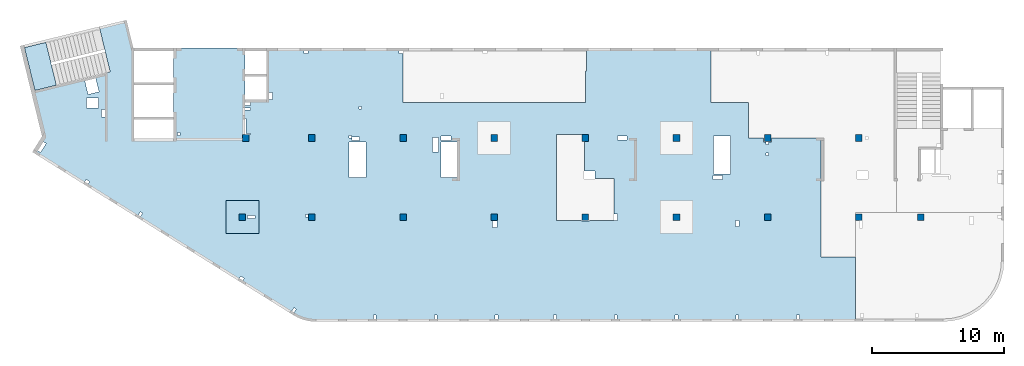
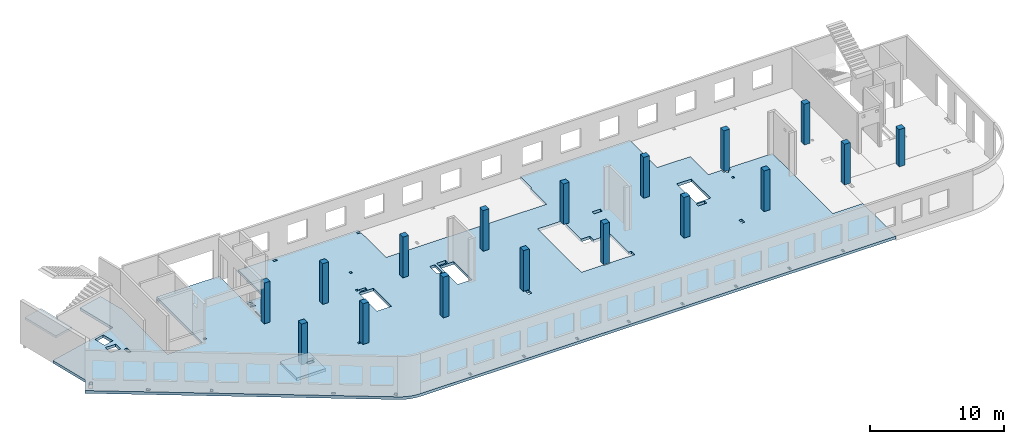
# One storey, part 1 of 6: 17 columns, 3 slabs.
"""IFC4 building model written with IfcOpenShell, lengths in millimetres."""

from ifc_helpers import new_model, entity, si_unit, converted_unit, derived_unit, direction, frame, origin, place, context, subcontext, project, spatial, indexed_curve, outline, extrude, source, transform, mapped, material, type_object, type_shapes, element, save


model = new_model("IFC4")

# Units and contexts
model_context = context("Model", 3, precision=0.01, world=origin(), true_north=direction((6.12303176911189e-17, 1.0)))
plan_context = context("Plan", 3, precision=0.01, world=origin(), true_north=direction((6.12303176911189e-17, 1.0)))
body_context = subcontext(model_context, "Body", "Model", "MODEL_VIEW")
ifc_project = project(units=[si_unit("LENGTHUNIT", "METRE", prefix="MILLI"), si_unit("AREAUNIT", "SQUARE_METRE"), si_unit("VOLUMEUNIT", "CUBIC_METRE"), converted_unit("PLANEANGLEUNIT", "DEGREE", entity("IfcRatioMeasure", 0.0174532925199433), si_unit("PLANEANGLEUNIT", "RADIAN"), dimensions=[0, 0, 0, 0, 0, 0, 0]), si_unit("MASSUNIT", "GRAM", prefix="KILO"), derived_unit("MASSDENSITYUNIT", [(si_unit("MASSUNIT", "GRAM", prefix="KILO"), 1), (si_unit("LENGTHUNIT", "METRE"), -3)]), derived_unit("MOMENTOFINERTIAUNIT", [(si_unit("LENGTHUNIT", "METRE"), 4)]), si_unit("TIMEUNIT", "SECOND"), si_unit("FREQUENCYUNIT", "HERTZ"), si_unit("THERMODYNAMICTEMPERATUREUNIT", "DEGREE_CELSIUS"), derived_unit("THERMALTRANSMITTANCEUNIT", [(si_unit("MASSUNIT", "GRAM", prefix="KILO"), 1), (si_unit("THERMODYNAMICTEMPERATUREUNIT", "KELVIN"), -1), (si_unit("TIMEUNIT", "SECOND"), -3)]), derived_unit("VOLUMETRICFLOWRATEUNIT", [(si_unit("LENGTHUNIT", "METRE"), 3), (si_unit("TIMEUNIT", "SECOND"), -1)]), derived_unit("MASSFLOWRATEUNIT", [(si_unit("MASSUNIT", "GRAM", prefix="KILO"), 1), (si_unit("TIMEUNIT", "SECOND"), -1)]), derived_unit("ROTATIONALFREQUENCYUNIT", [(si_unit("TIMEUNIT", "SECOND"), -1)]), si_unit("ELECTRICCURRENTUNIT", "AMPERE"), si_unit("ELECTRICVOLTAGEUNIT", "VOLT"), si_unit("POWERUNIT", "WATT"), si_unit("FORCEUNIT", "NEWTON", prefix="KILO"), si_unit("ILLUMINANCEUNIT", "LUX"), si_unit("LUMINOUSFLUXUNIT", "LUMEN"), si_unit("LUMINOUSINTENSITYUNIT", "CANDELA"), derived_unit("USERDEFINED", [(si_unit("MASSUNIT", "GRAM", prefix="KILO"), -1), (si_unit("LENGTHUNIT", "METRE"), -2), (si_unit("TIMEUNIT", "SECOND"), 3), (si_unit("LUMINOUSFLUXUNIT", "LUMEN"), 1)]), derived_unit("LINEARVELOCITYUNIT", [(si_unit("LENGTHUNIT", "METRE"), 1), (si_unit("TIMEUNIT", "SECOND"), -1)]), si_unit("PRESSUREUNIT", "PASCAL"), derived_unit("USERDEFINED", [(si_unit("LENGTHUNIT", "METRE"), -2), (si_unit("MASSUNIT", "GRAM", prefix="KILO"), 1), (si_unit("TIMEUNIT", "SECOND"), -2)]), derived_unit("LINEARFORCEUNIT", [(si_unit("MASSUNIT", "GRAM", prefix="KILO"), 1), (si_unit("LENGTHUNIT", "METRE"), 1), (si_unit("TIMEUNIT", "SECOND"), -2), (si_unit("LENGTHUNIT", "METRE"), -1)]), derived_unit("PLANARFORCEUNIT", [(si_unit("MASSUNIT", "GRAM", prefix="KILO"), 1), (si_unit("LENGTHUNIT", "METRE"), 1), (si_unit("TIMEUNIT", "SECOND"), -2), (si_unit("LENGTHUNIT", "METRE"), -2)])], contexts=[model_context, plan_context])

# Site, building, storey
site_placement = place(None, origin())
site = spatial("IfcSite", under=ifc_project, at=site_placement, CompositionType="ELEMENT")
building_placement = place(site_placement, origin())
building = spatial("IfcBuilding", under=site, at=building_placement, CompositionType="ELEMENT")
storey_placement = place(building_placement, frame((0.0, 0.0, 8100.0)))
storey = spatial("IfcBuildingStorey", under=building, at=storey_placement, CompositionType="ELEMENT", Elevation=8100.0)

# Columns
ifc_material = material()
column_type_1 = type_object("IfcColumnType", PredefinedType="COLUMN", material=ifc_material)
shared_shape_1 = source(origin(), body_context, "Body", "SweptSolid", [
    extrude(outline(indexed_curve([(-249.999999999999, -249.999999999999), (250.000000000001, -249.999999999999), (249.999999999999, 249.999999999999), (-250.000000000001, 249.999999999999), (-249.999999999999, -249.999999999999)], self_intersect=False)), frame((15899.9995239258, 7699.99922635584, 7950.0), z_axis=(0.0, 0.0, 1.0), x_axis=(0.0, -1.0, 0.0)), (0.0, 0.0, 1.0), 3700.0),
])
type_shapes(column_type_1, [shared_shape_1])
column_1_placement = place(storey_placement, frame((0.0, 0.0, -8100.0)))
element("IfcColumn", 1, at=column_1_placement, inside=storey, type_object=column_type_1, PredefinedType="COLUMN", context=body_context, shape_type="MappedRepresentation", body=[
    mapped(shared_shape_1, transform((0.0, 0.0, 0.0), scale=1.0)),
])
column_type_2 = type_object("IfcColumnType", PredefinedType="COLUMN", material=ifc_material)
shared_shape_2 = source(origin(), body_context, "Body", "SweptSolid", [
    extrude(outline(indexed_curve([(-249.999999999999, -249.999999999999), (250.000000000001, -249.999999999999), (249.999999999999, 249.999999999999), (-250.000000000001, 249.999999999999), (-249.999999999999, -249.999999999999)], self_intersect=False)), frame((21170.0002685547, 7699.99922635582, 7950.0), z_axis=(0.0, 0.0, 1.0), x_axis=(0.0, -1.0, 0.0)), (0.0, 0.0, 1.0), 3700.0),
])
type_shapes(column_type_2, [shared_shape_2])
column_2_placement = place(storey_placement, frame((0.0, 0.0, -8100.0)))
element("IfcColumn", 2, at=column_2_placement, inside=storey, type_object=column_type_2, PredefinedType="COLUMN", context=body_context, shape_type="MappedRepresentation", body=[
    mapped(shared_shape_2, transform((0.0, 0.0, 0.0), scale=1.0)),
])
column_type_3 = type_object("IfcColumnType", PredefinedType="COLUMN", material=ifc_material)
shared_shape_3 = source(origin(), body_context, "Body", "SweptSolid", [
    extrude(outline(indexed_curve([(-249.999999999999, -249.999999999999), (250.000000000001, -249.999999999999), (250.000000000001, 249.999999999999), (-249.999999999999, 249.999999999999), (-249.999999999999, -249.999999999999)], self_intersect=False)), frame((28070.0002685547, 7699.9992263558, 7950.0), z_axis=(0.0, 0.0, 1.0), x_axis=(0.0, -1.0, 0.0)), (0.0, 0.0, 1.0), 3700.0),
])
type_shapes(column_type_3, [shared_shape_3])
column_3_placement = place(storey_placement, frame((0.0, 0.0, -8100.0)))
element("IfcColumn", 3, at=column_3_placement, inside=storey, type_object=column_type_3, PredefinedType="COLUMN", context=body_context, shape_type="MappedRepresentation", body=[
    mapped(shared_shape_3, transform((0.0, 0.0, 0.0), scale=1.0)),
])
column_type_4 = type_object("IfcColumnType", PredefinedType="COLUMN", material=ifc_material)
shared_shape_4 = source(origin(), body_context, "Body", "SweptSolid", [
    extrude(outline(indexed_curve([(-249.999999999999, -249.999999999999), (250.000000000001, -249.999999999999), (249.999999999999, 249.999999999999), (-250.000000000001, 249.999999999999), (-249.999999999999, -249.999999999999)], self_intersect=False)), frame((34970.0002685547, 7699.99922635577, 7950.0), z_axis=(0.0, 0.0, 1.0), x_axis=(0.0, -1.0, 0.0)), (0.0, 0.0, 1.0), 3700.0),
])
type_shapes(column_type_4, [shared_shape_4])
column_4_placement = place(storey_placement, frame((0.0, 0.0, -8100.0)))
element("IfcColumn", 4, at=column_4_placement, inside=storey, type_object=column_type_4, PredefinedType="COLUMN", context=body_context, shape_type="MappedRepresentation", body=[
    mapped(shared_shape_4, transform((0.0, 0.0, 0.0), scale=1.0)),
])
column_type_5 = type_object("IfcColumnType", PredefinedType="COLUMN", material=ifc_material)
shared_shape_5 = source(origin(), body_context, "Body", "SweptSolid", [
    extrude(outline(indexed_curve([(-249.999999999999, -250.000000000004), (250.000000000001, -250.000000000004), (250.000000000001, 249.999999999995), (-249.999999999999, 250.000000000004), (-249.999999999999, -250.000000000004)], self_intersect=False)), frame((41870.0002685547, 7699.99922635575, 7950.0), z_axis=(0.0, 0.0, 1.0), x_axis=(0.0, -1.0, 0.0)), (0.0, 0.0, 1.0), 3700.0),
])
type_shapes(column_type_5, [shared_shape_5])
column_5_placement = place(storey_placement, frame((0.0, 0.0, -8100.0)))
element("IfcColumn", 5, at=column_5_placement, inside=storey, type_object=column_type_5, PredefinedType="COLUMN", context=body_context, shape_type="MappedRepresentation", body=[
    mapped(shared_shape_5, transform((0.0, 0.0, 0.0), scale=1.0)),
])
column_type_6 = type_object("IfcColumnType", PredefinedType="COLUMN", material=ifc_material)
shared_shape_6 = source(origin(), body_context, "Body", "SweptSolid", [
    extrude(outline(indexed_curve([(-249.999999999999, -250.000000000004), (250.000000000001, -250.000000000004), (249.999999999999, 249.999999999995), (-250.000000000001, 250.000000000004), (-249.999999999999, -250.000000000004)], self_intersect=False)), frame((48770.0002685547, 7699.99922635573, 7950.0), z_axis=(0.0, 0.0, 1.0), x_axis=(0.0, -1.0, 0.0)), (0.0, 0.0, 1.0), 3700.0),
])
type_shapes(column_type_6, [shared_shape_6])
column_6_placement = place(storey_placement, frame((0.0, 0.0, -8100.0)))
element("IfcColumn", 6, at=column_6_placement, inside=storey, type_object=column_type_6, PredefinedType="COLUMN", context=body_context, shape_type="MappedRepresentation", body=[
    mapped(shared_shape_6, transform((0.0, 0.0, 0.0), scale=1.0)),
])
column_type_7 = type_object("IfcColumnType", PredefinedType="COLUMN", material=ifc_material)
shared_shape_7 = source(origin(), body_context, "Body", "SweptSolid", [
    extrude(outline(indexed_curve([(-249.999999999999, -250.000000000004), (250.000000000001, -250.000000000004), (250.000000000001, 249.999999999995), (-249.999999999999, 250.000000000004), (-249.999999999999, -250.000000000004)], self_intersect=False)), frame((55670.0002685547, 7699.99922635571, 7950.0), z_axis=(0.0, 0.0, 1.0), x_axis=(0.0, -1.0, 0.0)), (0.0, 0.0, 1.0), 3700.0),
])
type_shapes(column_type_7, [shared_shape_7])
column_7_placement = place(storey_placement, frame((0.0, 0.0, -8100.0)))
element("IfcColumn", 7, at=column_7_placement, inside=storey, type_object=column_type_7, PredefinedType="COLUMN", context=body_context, shape_type="MappedRepresentation", body=[
    mapped(shared_shape_7, transform((0.0, 0.0, 0.0), scale=1.0)),
])
column_type_8 = type_object("IfcColumnType", PredefinedType="COLUMN", material=ifc_material)
shared_shape_8 = source(origin(), body_context, "Body", "SweptSolid", [
    extrude(outline(indexed_curve([(-249.999999999999, -250.000000000004), (250.000000000001, -250.000000000004), (249.999999999999, 249.999999999995), (-250.000000000001, 250.000000000004), (-249.999999999999, -250.000000000004)], self_intersect=False)), frame((62570.0002685547, 7699.99922635568, 7950.0), z_axis=(0.0, 0.0, 1.0), x_axis=(0.0, -1.0, 0.0)), (0.0, 0.0, 1.0), 3700.0),
])
type_shapes(column_type_8, [shared_shape_8])
column_8_placement = place(storey_placement, frame((0.0, 0.0, -8100.0)))
element("IfcColumn", 8, at=column_8_placement, inside=storey, type_object=column_type_8, PredefinedType="COLUMN", context=body_context, shape_type="MappedRepresentation", body=[
    mapped(shared_shape_8, transform((0.0, 0.0, 0.0), scale=1.0)),
])
column_type_9 = type_object("IfcColumnType", PredefinedType="COLUMN", material=ifc_material)
shared_shape_9 = source(origin(), body_context, "Body", "SweptSolid", [
    extrude(outline(indexed_curve([(-249.999999999999, -250.000000000004), (250.000000000001, -250.000000000004), (249.999999999999, 249.999999999995), (-250.000000000001, 250.000000000004), (-249.999999999999, -250.000000000004)], self_intersect=False)), frame((67270.0002685547, 7699.99922635567, 7950.0), z_axis=(0.0, 0.0, 1.0), x_axis=(0.0, -1.0, 0.0)), (0.0, 0.0, 1.0), 3400.0),
])
type_shapes(column_type_9, [shared_shape_9])
column_9_placement = place(storey_placement, frame((0.0, 0.0, -8100.0)))
element("IfcColumn", 9, at=column_9_placement, inside=storey, type_object=column_type_9, PredefinedType="COLUMN", context=body_context, shape_type="MappedRepresentation", body=[
    mapped(shared_shape_9, transform((0.0, 0.0, 0.0), scale=1.0)),
])
column_type_10 = type_object("IfcColumnType", PredefinedType="COLUMN", material=ifc_material)
shared_shape_10 = source(origin(), body_context, "Body", "SweptSolid", [
    extrude(outline(indexed_curve([(-249.999999999999, -250.000000000004), (249.999999999999, -250.000000000004), (249.999999999999, 249.999999999995), (-249.999999999999, 250.000000000004), (-249.999999999999, -250.000000000004)], self_intersect=False)), frame((62570.0002685547, 13699.9992263555, 7950.0), z_axis=(0.0, 0.0, 1.0), x_axis=(0.0, -1.0, 0.0)), (0.0, 0.0, 1.0), 3700.0),
])
type_shapes(column_type_10, [shared_shape_10])
column_10_placement = place(storey_placement, frame((0.0, 0.0, -8100.0)))
element("IfcColumn", 10, at=column_10_placement, inside=storey, type_object=column_type_10, PredefinedType="COLUMN", context=body_context, shape_type="MappedRepresentation", body=[
    mapped(shared_shape_10, transform((0.0, 0.0, 0.0), scale=1.0)),
])
column_type_11 = type_object("IfcColumnType", PredefinedType="COLUMN", material=ifc_material)
shared_shape_11 = source(origin(), body_context, "Body", "SweptSolid", [
    extrude(outline(indexed_curve([(-249.999999999999, -250.000000000004), (249.999999999999, -250.000000000004), (249.999999999999, 249.999999999995), (-249.999999999999, 250.000000000004), (-249.999999999999, -250.000000000004)], self_intersect=False)), frame((55670.0002685547, 13699.9992263555, 7950.0), z_axis=(0.0, 0.0, 1.0), x_axis=(0.0, -1.0, 0.0)), (0.0, 0.0, 1.0), 3700.0),
])
type_shapes(column_type_11, [shared_shape_11])
column_11_placement = place(storey_placement, frame((0.0, 0.0, -8100.0)))
element("IfcColumn", 11, at=column_11_placement, inside=storey, type_object=column_type_11, PredefinedType="COLUMN", context=body_context, shape_type="MappedRepresentation", body=[
    mapped(shared_shape_11, transform((0.0, 0.0, 0.0), scale=1.0)),
])
column_type_12 = type_object("IfcColumnType", PredefinedType="COLUMN", material=ifc_material)
shared_shape_12 = source(origin(), body_context, "Body", "SweptSolid", [
    extrude(outline(indexed_curve([(-249.999999999999, -250.000000000004), (249.999999999999, -250.000000000004), (249.999999999999, 249.999999999995), (-249.999999999999, 250.000000000004), (-249.999999999999, -250.000000000004)], self_intersect=False)), frame((48770.0002685547, 13699.9992263556, 7950.0), z_axis=(0.0, 0.0, 1.0), x_axis=(0.0, -1.0, 0.0)), (0.0, 0.0, 1.0), 3700.0),
])
type_shapes(column_type_12, [shared_shape_12])
column_12_placement = place(storey_placement, frame((0.0, 0.0, -8100.0)))
element("IfcColumn", 12, at=column_12_placement, inside=storey, type_object=column_type_12, PredefinedType="COLUMN", context=body_context, shape_type="MappedRepresentation", body=[
    mapped(shared_shape_12, transform((0.0, 0.0, 0.0), scale=1.0)),
])
column_type_13 = type_object("IfcColumnType", PredefinedType="COLUMN", material=ifc_material)
shared_shape_13 = source(origin(), body_context, "Body", "SweptSolid", [
    extrude(outline(indexed_curve([(-249.999999999999, -250.000000000004), (249.999999999999, -250.000000000004), (249.999999999999, 249.999999999995), (-249.999999999999, 250.000000000004), (-249.999999999999, -250.000000000004)], self_intersect=False)), frame((41870.0002685547, 13699.9992263556, 7950.0), z_axis=(0.0, 0.0, 1.0), x_axis=(0.0, -1.0, 0.0)), (0.0, 0.0, 1.0), 3700.0),
])
type_shapes(column_type_13, [shared_shape_13])
column_13_placement = place(storey_placement, frame((0.0, 0.0, -8100.0)))
element("IfcColumn", 13, at=column_13_placement, inside=storey, type_object=column_type_13, PredefinedType="COLUMN", context=body_context, shape_type="MappedRepresentation", body=[
    mapped(shared_shape_13, transform((0.0, 0.0, 0.0), scale=1.0)),
])
column_type_14 = type_object("IfcColumnType", PredefinedType="COLUMN", material=ifc_material)
shared_shape_14 = source(origin(), body_context, "Body", "SweptSolid", [
    extrude(outline(indexed_curve([(-249.999999999999, -249.999999999999), (249.999999999999, -249.999999999999), (249.999999999999, 249.999999999999), (-249.999999999999, 249.999999999999), (-249.999999999999, -249.999999999999)], self_intersect=False)), frame((34970.0002685547, 13699.9992263556, 7950.0), z_axis=(0.0, 0.0, 1.0), x_axis=(0.0, -1.0, 0.0)), (0.0, 0.0, 1.0), 3700.0),
])
type_shapes(column_type_14, [shared_shape_14])
column_14_placement = place(storey_placement, frame((0.0, 0.0, -8100.0)))
element("IfcColumn", 14, at=column_14_placement, inside=storey, type_object=column_type_14, PredefinedType="COLUMN", context=body_context, shape_type="MappedRepresentation", body=[
    mapped(shared_shape_14, transform((0.0, 0.0, 0.0), scale=1.0)),
])
column_type_15 = type_object("IfcColumnType", PredefinedType="COLUMN", material=ifc_material)
shared_shape_15 = source(origin(), body_context, "Body", "SweptSolid", [
    extrude(outline(indexed_curve([(-249.999999999999, -249.999999999999), (249.999999999999, -249.999999999999), (249.999999999999, 249.999999999999), (-249.999999999999, 249.999999999999), (-249.999999999999, -249.999999999999)], self_intersect=False)), frame((28070.0002685547, 13699.9992263556, 7950.0), z_axis=(0.0, 0.0, 1.0), x_axis=(0.0, -1.0, 0.0)), (0.0, 0.0, 1.0), 3700.0),
])
type_shapes(column_type_15, [shared_shape_15])
column_15_placement = place(storey_placement, frame((0.0, 0.0, -8100.0)))
element("IfcColumn", 15, at=column_15_placement, inside=storey, type_object=column_type_15, PredefinedType="COLUMN", context=body_context, shape_type="MappedRepresentation", body=[
    mapped(shared_shape_15, transform((0.0, 0.0, 0.0), scale=1.0)),
])
column_type_16 = type_object("IfcColumnType", PredefinedType="COLUMN", material=ifc_material)
shared_shape_16 = source(origin(), body_context, "Body", "SweptSolid", [
    extrude(outline(indexed_curve([(-249.999999999999, -249.999999999999), (249.999999999999, -249.999999999999), (249.999999999999, 249.999999999999), (-249.999999999999, 249.999999999999), (-249.999999999999, -249.999999999999)], self_intersect=False)), frame((21170.0002685547, 13699.9992263556, 7950.0), z_axis=(0.0, 0.0, 1.0), x_axis=(0.0, -1.0, 0.0)), (0.0, 0.0, 1.0), 3700.0),
])
type_shapes(column_type_16, [shared_shape_16])
column_16_placement = place(storey_placement, frame((0.0, 0.0, -8100.0)))
element("IfcColumn", 16, at=column_16_placement, inside=storey, type_object=column_type_16, PredefinedType="COLUMN", context=body_context, shape_type="MappedRepresentation", body=[
    mapped(shared_shape_16, transform((0.0, 0.0, 0.0), scale=1.0)),
])
column_type_17 = type_object("IfcColumnType", PredefinedType="COLUMN", material=ifc_material)
shared_shape_17 = source(origin(), body_context, "Body", "SweptSolid", [
    extrude(outline(indexed_curve([(-249.999999999999, -249.999999999999), (249.999999999999, -249.999999999999), (249.999999999999, 249.999999999999), (-249.999999999999, 249.999999999999), (-249.999999999999, -249.999999999999)], self_intersect=False)), frame((16160.0002685547, 13699.9992263558, 7950.0), z_axis=(0.0, 0.0, 1.0), x_axis=(0.0, -1.0, 0.0)), (0.0, 0.0, 1.0), 3700.0),
])
type_shapes(column_type_17, [shared_shape_17])
column_17_placement = place(storey_placement, frame((0.0, 0.0, -8100.0)))
element("IfcColumn", 17, at=column_17_placement, inside=storey, type_object=column_type_17, PredefinedType="COLUMN", context=body_context, shape_type="MappedRepresentation", body=[
    mapped(shared_shape_17, transform((0.0, 0.0, 0.0), scale=1.0)),
])

# Slabs
slab_type_1 = type_object("IfcSlabType", PredefinedType="FLOOR", material=ifc_material)
slab_1_placement = place(storey_placement, origin())
element("IfcSlab", 18, at=slab_1_placement, inside=storey, type_object=slab_type_1, material=ifc_material, PredefinedType="FLOOR", context=body_context, shape_type="SweptSolid", body=[
    extrude(outline(indexed_curve([(-4918.44093092507, 21194.7161822057), (-4918.44093092504, 15794.7161822057), (-1018.44093092502, 15794.7161822057), (-1018.44093092502, 14169.7161822057), (-4918.44093092503, 14169.7161822057), (-4918.44093092499, 3824.71618220575), (-4718.44157029135, 3824.71618220575), (-4718.44157029135, 4124.71618220581), (-4518.44197312357, 4124.71618220581), (-4518.44197312357, 3824.71618220575), (-818.440930924992, 3824.71618220575), (-818.440930924947, -9975.28381779424), (-3198.44093092485, -9975.28381779424), (-3198.44093092485, -10075.2838177942), (-4918.44093092494, -10075.2838177942), (-4918.44093092491, -19495.2838177944), (-818.440930924876, -19495.2838177942), (-818.440930924728, -22325.2838177944), (1881.5590690752, -22325.2838177942), (1881.55906907526, -23475.2838177943), (2181.5590690751, -23475.2838177943), (2181.5590690751, -23650.2838177942), (2371.55802687642, -23650.2838177942), (2371.55802687642, -23850.2838177942), (2181.5590690751, -23850.2838177942), (2181.5590690751, -24075.2838177943), (1881.55906907526, -24075.2838177943), (1881.55906907527, -27835.2838177942), (10881.5590690753, -27835.2838177942), (10881.5590690753, -30425.2838177942), (15782.0128580296, -30425.2838177942), (15782.0128580296, 10427.6716031478), (15777.0106740912, 10606.4915509534), (15762.0197669795, 10784.7522260372), (15737.0870218744, 10961.8961048444), (15702.2904177954, 11137.3691566841), (15657.7387837167, 11310.6225765011), (15603.5714581962, 11481.1145013049), (15539.9578535838, 11648.3117048867), (15467.0969261719, 11811.691265524), (15385.2165539443, 11970.7422014573), (15294.5728238713, 12124.9670690234), (2942.09072966658, 31894.8565409199), (1763.37987869352, 31158.3306297265), (-1646.92724838292, 31989.6290722903), (-3108.1423640225, 25995.1605782929), (-6547.43664984333, 26833.5249474787), (-7051.87622791275, 24764.1190636373), (-4918.44093092509, 24244.0716386956), (-4918.44093092509, 24194.7161822057), (1931.55906907492, 24194.7161822058), (1931.55906907493, 21194.7161822057), (-4918.44093092507, 21194.7161822057)], self_intersect=False), holes=[indexed_curve([(1631.55906907515, -7800.28381779424), (7881.55906907513, -7800.28381779422), (8131.55906907513, -7800.28381779422), (8131.55906907513, -9675.28381779422), (8181.55906907513, -9675.28381779422), (8181.55906907513, -9975.28381779428), (8181.55906907513, -10275.2838177943), (8131.55906907513, -10275.2838177943), (8131.55802687643, -12400.2838177942), (7631.55802687644, -12400.2838177942), (7631.55802687644, -12150.2838177943), (4956.55906907508, -12150.2838177943), (4956.55906907509, -10690.2838177942), (4396.55906907515, -10690.2838177942), (4396.55906907515, -9925.28381779424), (2081.55906907572, -9925.28381779424), (2081.55906907572, -10225.2838177943), (1631.55906907515, -10225.2838177943), (1631.55906907515, -7800.28381779424)], self_intersect=False), indexed_curve([(-2433.4077366988, 27918.680956152), (-1413.3021088605, 27670.0194168614), (-1614.60687707192, 26844.1895456677), (-2634.71250491022, 27092.8510849583), (-2433.4077366988, 27918.680956152)], self_intersect=False), indexed_curve([(-1128.44197312358, 26884.7161822058), (-1128.44197312358, 27784.7161822058), (-388.441973123572, 27784.7161822058), (-388.441973123572, 26884.7161822058), (-1128.44197312358, 26884.7161822058)], self_intersect=False), indexed_curve([(-268.441973123565, 26394.7161822058), (-268.441973123565, 26644.7161822058), (291.558026876412, 26644.7161822058), (291.558026876412, 26394.7161822058), (-268.441973123565, 26394.7161822058)], self_intersect=False), indexed_curve([(2300.46693601222, 30845.3844889143), (2167.98706279423, 31057.4007421437), (2846.42925781629, 31481.3302032733), (2978.90913103428, 31269.313950044), (2300.46693601222, 30845.3844889143)], self_intersect=False), indexed_curve([(7467.44226277405, 23709.0856761198), (7721.85808590733, 23868.0592240434), (7827.84184543901, 23698.4464439791), (7573.42602230574, 23539.4728960555), (7467.44226277405, 23709.0856761198)], self_intersect=False), indexed_curve([(12496.324877766, 15849.7447590121), (12337.3522593331, 16104.1590946203), (12506.9628080886, 16210.1414599027), (12665.9354265215, 15955.7271242945), (12496.324877766, 15849.7447590121)], self_intersect=False), indexed_curve([(14729.8838440301, 12086.5228222013), (14984.2996671633, 12245.4963701249), (15090.283426695, 12075.8835900606), (14835.8676035617, 11916.910042137), (14729.8838440301, 12086.5228222013)], self_intersect=False), indexed_curve([(7731.55802687642, 15044.7161822058), (7731.55802687642, 15604.7161822058), (7981.55802687643, 15604.7161822058), (7981.55802687643, 15044.7161822058), (7731.55802687642, 15044.7161822058)], self_intersect=False), indexed_curve([(1481.55802687642, 20694.7161822058), (1481.55802687642, 20894.7161822058), (1681.55802687644, 20894.7161822058), (1681.55802687644, 20694.7161822058), (1481.55802687642, 20694.7161822058)], self_intersect=False), indexed_curve([(-818.440930924518, 15364.7161822058), (-818.440930924518, 15794.7161822057), (-568.441973123566, 15794.7161822057), (-568.441973123566, 15364.7161822058), (-818.440930924518, 15364.7161822058)], self_intersect=False), indexed_curve([(421.558026876417, 15714.7161822058), (421.558026876417, 15794.7161822057), (1611.55802687642, 15794.7161822057), (1611.55802687642, 15374.7161822058), (1531.55802687644, 15374.7161822058), (1531.55802687644, 15714.7161822058), (421.558026876417, 15714.7161822058)], self_intersect=False), indexed_curve([(-4718.44157029133, 11024.7161822058), (-4718.44157029133, 11324.7161822058), (-4518.44197312357, 11324.7161822058), (-4518.44197312357, 11024.7161822058), (-4718.44157029133, 11024.7161822058)], self_intersect=False), indexed_curve([(7681.55802687643, 11004.7161822058), (7681.55802687643, 11204.7161822058), (7881.559069075, 11204.7161822058), (7881.559069075, 11004.7161822058), (7681.55802687643, 11004.7161822058)], self_intersect=False), indexed_curve([(15281.5580268764, 5854.7161822058), (15281.5580268764, 6054.71618220579), (15581.5582512046, 6054.71618220579), (15581.5582512046, 5854.7161822058), (15281.5580268764, 5854.7161822058)], self_intersect=False), indexed_curve([(15581.5582512046, 1244.71651640657), (15281.5580268764, 1244.71651640657), (15281.5580268764, 1444.71651640656), (15581.5582512046, 1444.71651640656), (15581.5582512046, 1244.71651640657)], self_intersect=False), indexed_curve([(15581.5590690751, -3345.28348359343), (15281.5582857487, -3345.28348359343), (15281.5582857487, -3145.28348359344), (15581.5590690751, -3145.28348359344), (15581.5590690751, -3345.28348359343)], self_intersect=False), indexed_curve([(15581.5590690751, -7775.28381779419), (15281.5582857487, -7775.28381779419), (15281.5582857487, -7575.2838177942), (15581.5590690751, -7575.2838177942), (15581.5590690751, -7775.28381779419)], self_intersect=False), indexed_curve([(15581.5582512047, -12375.2834835934), (15281.5582857487, -12375.2834835934), (15281.5582857487, -12175.2834835934), (15581.5582512047, -12175.2834835934), (15581.5582512047, -12375.2834835934)], self_intersect=False), indexed_curve([(15581.5582512047, -16975.2838177942), (15281.5582857487, -16975.2838177942), (15281.5582857487, -16775.2838177942), (15581.5582512047, -16775.2838177942), (15581.5582512047, -16975.2838177942)], self_intersect=False), indexed_curve([(15281.5582857487, -21575.2834835934), (15281.5582857487, -21375.2834835934), (15581.5582512047, -21375.2834835934), (15581.5582512047, -21575.2834835934), (15281.5582857487, -21575.2834835934)], self_intersect=False), indexed_curve([(15281.5582857487, -26175.2834835934), (15281.5582857487, -25975.2834835934), (15581.5582512047, -25975.2834835934), (15581.5582512047, -26175.2834835934), (15281.5582857487, -26175.2834835934)], self_intersect=False), indexed_curve([(8581.55802687643, -21600.2838177942), (8131.55802687643, -21600.2838177942), (8131.55802687643, -21350.2838177942), (8581.55802687643, -21350.2838177942), (8581.55802687643, -21600.2838177942)], self_intersect=False), indexed_curve([(4731.55802687644, -20375.2838177942), (4731.55802687644, -19645.2838177942), (5031.55802687644, -19645.2838177942), (5031.55802687644, -20375.2838177942), (4731.55802687644, -20375.2838177942)], self_intersect=False), indexed_curve([(4606.55802687642, -20955.2838177942), (1746.55802687645, -20955.2838177942), (1746.55802687645, -19695.2838177942), (4606.55802687642, -19695.2838177942), (4606.55802687642, -20955.2838177942)], self_intersect=False), indexed_curve([(3001.55802687642, -23850.2838177942), (3001.55802687642, -23650.2838177942), (3201.55802687644, -23650.2838177942), (3201.55802687644, -23850.2838177942), (3001.55802687642, -23850.2838177942)], self_intersect=False), indexed_curve([(1741.55802687643, -13135.2838177942), (1741.55802687643, -12415.2838177942), (2031.55802687643, -12415.2838177942), (2031.55802687643, -13135.2838177942), (1741.55802687643, -13135.2838177942)], self_intersect=False), indexed_curve([(8641.55802687642, -3275.2838177942), (8181.55802687642, -3275.2838177942), (8181.55802687642, -2955.28381779421), (8641.55802687642, -2955.28381779421), (8641.55802687642, -3275.2838177942)], self_intersect=False), indexed_curve([(2181.55802687643, -275.283817794194), (2181.55802687643, 944.716182205806), (4891.55802687644, 944.716182205806), (4891.55802687644, -275.283817794194), (2181.55802687643, -275.283817794194)], self_intersect=False), indexed_curve([(2931.55802687644, 1144.7161822058), (1831.55802687644, 1144.7161822058), (1831.55802687644, 1604.71618220579), (2931.55802687644, 1604.71618220579), (2931.55802687644, 1144.7161822058)], self_intersect=False), indexed_curve([(1741.55802687643, 184.716182205805), (1741.55802687643, 944.716182205806), (2061.55802687643, 944.716182205806), (2061.55802687643, 184.716182205805), (1741.55802687643, 184.716182205805)], self_intersect=False), indexed_curve([(2181.55802687643, 6644.71618220579), (2181.55802687643, 7904.71618220578), (4891.55802687644, 7904.71618220578), (4891.55802687644, 6644.71618220579), (2181.55802687643, 6644.71618220579)], self_intersect=False), indexed_curve([(1691.55802687644, 7724.71618220579), (1691.55802687644, 7924.71618220581), (1891.55802687643, 7924.71618220581), (1891.55802687643, 7724.71618220579), (1691.55802687644, 7724.71618220579)], self_intersect=False), indexed_curve([(1811.55802687641, 7124.71618220579), (1811.55802687641, 7684.7161822058), (2061.55802687643, 7684.7161822058), (2061.55802687643, 7124.71618220579), (1811.55802687641, 7124.71618220579)], self_intersect=False), indexed_curve([(-518.441973123577, 6974.71618220579), (-518.441973123577, 7174.71618220581), (-318.441973123588, 7174.71618220581), (-318.441973123588, 6974.71618220579), (-518.441973123577, 6974.71618220579)], self_intersect=False), indexed_curve([(-393.441973123588, 15794.7161822058), (-233.441973123555, 15794.7161822058), (-233.441973123555, 15364.7161822058), (-393.441973123588, 15364.7161822058), (-393.441973123588, 15794.7161822058)], self_intersect=False), indexed_curve([(-1578.44197312358, 13969.7161822057), (-1018.44093092451, 13969.7161822057), (-1018.44093092451, 13719.7161822059), (-1578.44197312358, 13719.7161822059), (-1578.44197312358, 13969.7161822057)], self_intersect=False), indexed_curve([(5194.17744481265, 27913.2727788869), (5353.15222175436, 27658.8549888751), (5183.35238030296, 27552.7543426969), (5024.37760336126, 27807.1721327087), (5194.17744481265, 27913.2727788869)], self_intersect=False)]), frame((31894.7164507604, 15581.5582954313, -400.0), z_axis=(0.0, 0.0, -1.0), x_axis=(0.0, -1.0, 0.0)), (0.0, 0.0, -1.0), 249.999999999999),
])
slab_type_2 = type_object("IfcSlabType", PredefinedType="FLOOR", material=ifc_material)
slab_2_placement = place(storey_placement, origin())
element("IfcSlab", 19, at=slab_2_placement, inside=storey, type_object=slab_type_2, material=ifc_material, PredefinedType="FLOOR", context=body_context, shape_type="SweptSolid", body=[
    extrude(outline(indexed_curve([(-1250.0, -1250.0), (1250.0, -1250.0), (1250.0, 1250.0), (-1250.0, 1250.0), (-1250.0, -1250.0)], self_intersect=False), holes=[indexed_curve([(-949.999999999979, -150.001042198552), (-949.999999999979, 99.9989578014607), (-389.999999999968, 99.9989578014607), (-389.999999999968, -150.001042198552), (-949.999999999979, -150.001042198552)], self_intersect=False)]), frame((15900.0002685547, 7699.99922635634, -650.0), z_axis=(0.0, 0.0, 1.0), x_axis=(-1.0, 0.0, 0.0)), (0.0, 0.0, 1.0), 250.000000000001),
])
slab_type_3 = type_object("IfcSlabType", PredefinedType="FLOOR", material=ifc_material)
slab_3_placement = place(storey_placement, origin())
element("IfcSlab", 20, at=slab_3_placement, inside=storey, type_object=slab_type_3, material=ifc_material, PredefinedType="FLOOR", context=body_context, shape_type="SweptSolid", body=[
    extrude(outline(indexed_curve([(-835.0, -1670.00000000002), (835.0, -1670.00000000002), (835.0, 1670.00000000002), (-835.000000000001, 1670.00000000002), (-835.0, -1670.00000000002)], self_intersect=False)), frame((612.299389166834, 19119.7750964545, 1920.0), z_axis=(0.0, 0.0, -1.0), x_axis=(0.971552058141474, 0.236826092990333, 0.0)), (0.0, 0.0, 1.0), 200.0),
])

save(model, "model.ifc")
